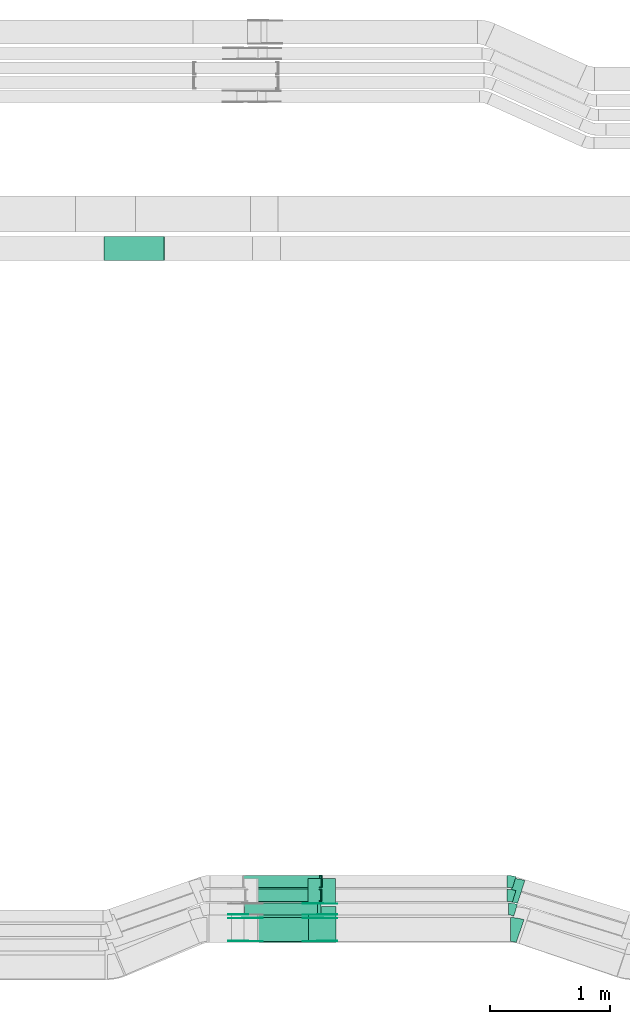
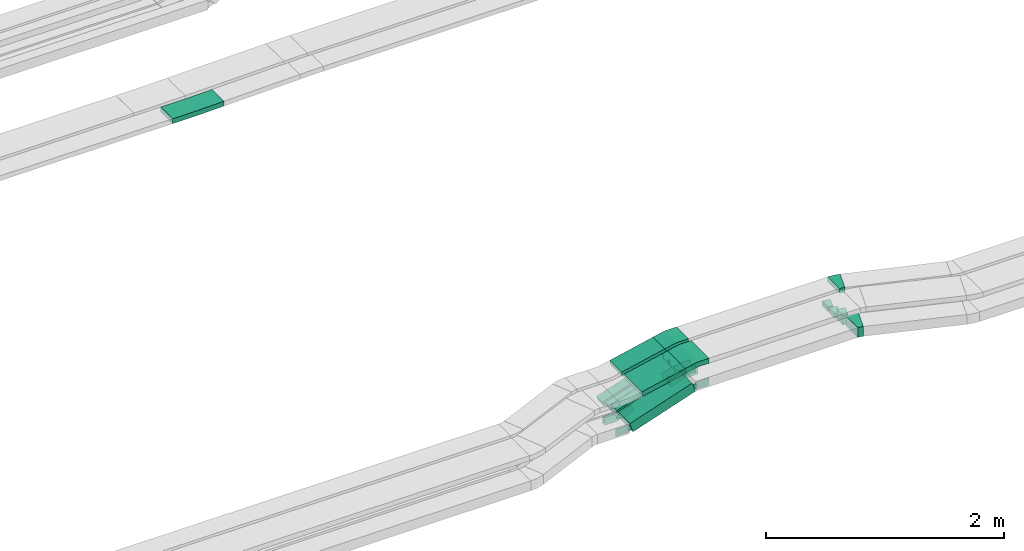
# One storey, part 10 of 28: 23 flow fittings, 6 flow segments.
"""IFC2X3 building model written with IfcOpenShell, lengths in millimetres."""

from ifc_helpers import new_model, entity, si_unit, converted_unit, derived_unit, direction, frame, frame_2d, origin, origin_2d_with_axis, place, context, subcontext, project, spatial, polyline, circle_curve, parameter, trimmed, segment, composite_curve, rectangle, outline, extrude, faceted_brep, source, transform, mapped, material, type_object, type_shapes, element, save


model = new_model("IFC2X3")

# Units and contexts
model_context = context("Model", 3, precision=0.01, world=origin(), true_north=direction((6.12303176911189e-17, 1.0)))
body_context = subcontext(model_context, "Body", "Model", "MODEL_VIEW")
ifc_project = project(units=[si_unit("LENGTHUNIT", "METRE", prefix="MILLI"), si_unit("AREAUNIT", "SQUARE_METRE"), si_unit("VOLUMEUNIT", "CUBIC_METRE"), converted_unit("PLANEANGLEUNIT", "DEGREE", entity("IfcRatioMeasure", 0.0174532925199433), si_unit("PLANEANGLEUNIT", "RADIAN"), dimensions=[0, 0, 0, 0, 0, 0, 0]), si_unit("MASSUNIT", "GRAM", prefix="KILO"), derived_unit("MASSDENSITYUNIT", [(si_unit("MASSUNIT", "GRAM", prefix="KILO"), 1), (si_unit("LENGTHUNIT", "METRE"), -3)]), derived_unit("MOMENTOFINERTIAUNIT", [(si_unit("LENGTHUNIT", "METRE"), 4)]), si_unit("TIMEUNIT", "SECOND"), si_unit("FREQUENCYUNIT", "HERTZ"), si_unit("THERMODYNAMICTEMPERATUREUNIT", "DEGREE_CELSIUS"), derived_unit("THERMALTRANSMITTANCEUNIT", [(si_unit("MASSUNIT", "GRAM", prefix="KILO"), 1), (si_unit("THERMODYNAMICTEMPERATUREUNIT", "KELVIN"), -1), (si_unit("TIMEUNIT", "SECOND"), -3)]), derived_unit("VOLUMETRICFLOWRATEUNIT", [(si_unit("LENGTHUNIT", "METRE"), 3), (si_unit("TIMEUNIT", "SECOND"), -1)]), derived_unit("MASSFLOWRATEUNIT", [(si_unit("MASSUNIT", "GRAM", prefix="KILO"), 1), (si_unit("TIMEUNIT", "SECOND"), -1)]), derived_unit("ROTATIONALFREQUENCYUNIT", [(si_unit("TIMEUNIT", "SECOND"), -1)]), si_unit("ELECTRICCURRENTUNIT", "AMPERE"), si_unit("ELECTRICVOLTAGEUNIT", "VOLT"), si_unit("POWERUNIT", "WATT"), si_unit("FORCEUNIT", "NEWTON", prefix="KILO"), si_unit("ILLUMINANCEUNIT", "LUX"), si_unit("LUMINOUSFLUXUNIT", "LUMEN"), si_unit("LUMINOUSINTENSITYUNIT", "CANDELA"), derived_unit("USERDEFINED", [(si_unit("MASSUNIT", "GRAM", prefix="KILO"), -1), (si_unit("LENGTHUNIT", "METRE"), -2), (si_unit("TIMEUNIT", "SECOND"), 3), (si_unit("LUMINOUSFLUXUNIT", "LUMEN"), 1)]), derived_unit("LINEARVELOCITYUNIT", [(si_unit("LENGTHUNIT", "METRE"), 1), (si_unit("TIMEUNIT", "SECOND"), -1)]), si_unit("PRESSUREUNIT", "PASCAL"), derived_unit("USERDEFINED", [(si_unit("LENGTHUNIT", "METRE"), -2), (si_unit("MASSUNIT", "GRAM", prefix="KILO"), 1), (si_unit("TIMEUNIT", "SECOND"), -2)]), derived_unit("LINEARFORCEUNIT", [(si_unit("MASSUNIT", "GRAM", prefix="KILO"), 1), (si_unit("LENGTHUNIT", "METRE"), 1), (si_unit("TIMEUNIT", "SECOND"), -2), (si_unit("LENGTHUNIT", "METRE"), -1)]), derived_unit("PLANARFORCEUNIT", [(si_unit("MASSUNIT", "GRAM", prefix="KILO"), 1), (si_unit("LENGTHUNIT", "METRE"), 1), (si_unit("TIMEUNIT", "SECOND"), -2), (si_unit("LENGTHUNIT", "METRE"), -2)])], contexts=[model_context])

# Site, building, storey
site_placement = place(None, origin())
site = spatial("IfcSite", under=ifc_project, at=site_placement, CompositionType="ELEMENT")
building_placement = place(site_placement, origin())
building = spatial("IfcBuilding", under=site, at=building_placement, CompositionType="ELEMENT")
storey_placement = place(building_placement, frame((0.0, 0.0, 15900.0)))
storey = spatial("IfcBuildingStorey", under=building, at=storey_placement, CompositionType="ELEMENT", Elevation=15900.0)

# Flow segments
cable_carrier_segment_type = type_object("IfcCableCarrierSegmentType", PredefinedType="CABLETRAYSEGMENT")
flow_segment_1_placement = place(storey_placement, frame((34367.86, 8525.15, 2844.72)))
element("IfcFlowSegment", 1, at=flow_segment_1_placement, inside=storey, type_object=cable_carrier_segment_type, context=body_context, shape_type="SweptSolid", body=[
    extrude(rectangle(XDim=50.0000000000015, YDim=300.000000000001, at=origin_2d_with_axis()), frame((5.31, 150.0, 24.43), z_axis=(0.977163348612744, 0.0, 0.212489505924243), x_axis=(-0.212489505924243, 0.0, 0.977163348612744)), (0.0, 0.0, 1.0), 431.573113149383),
])
flow_segment_2_placement = place(storey_placement, frame((34257.02, 8534.97, 2505.75)))
element("IfcFlowSegment", 2, at=flow_segment_2_placement, inside=storey, type_object=cable_carrier_segment_type, context=body_context, shape_type="SweptSolid", body=[
    extrude(rectangle(XDim=100.000000000002, YDim=200.0, at=origin_2d_with_axis()), frame((15.95, 100.0, 47.39), z_axis=(0.947738671950759, 0.0, 0.319047660528974), x_axis=(-0.319047660528974, 0.0, 0.947738671950759)), (0.0, 0.0, 1.0), 638.51802239172),
])
flow_segment_3_placement = place(storey_placement, frame((34364.23, 8860.15, 2844.77)))
element("IfcFlowSegment", 3, at=flow_segment_3_placement, inside=storey, type_object=cable_carrier_segment_type, context=body_context, shape_type="SweptSolid", body=[
    extrude(rectangle(XDim=50.0000000000002, YDim=200.0, at=origin_2d_with_axis()), frame((5.32, 100.0, 24.43), z_axis=(0.97707606826074, 0.0, 0.212890480839644), x_axis=(-0.212890480839644, 0.0, 0.97707606826074)), (0.0, 0.0, 1.0), 430.332278002831),
])
flow_segment_4_placement = place(storey_placement, frame((34259.3, 8755.15, 2505.75)))
element("IfcFlowSegment", 4, at=flow_segment_4_placement, inside=storey, type_object=cable_carrier_segment_type, context=body_context, shape_type="SweptSolid", body=[
    extrude(rectangle(XDim=100.0, YDim=99.9999999999989, at=origin_2d_with_axis()), frame((15.95, 50.0, 47.39), z_axis=(0.947738671950757, 0.0, 0.319047660528981), x_axis=(-0.319047660528981, 0.0, 0.947738671950757)), (0.0, 0.0, 1.0), 638.518022391706),
])
flow_segment_5_placement = place(storey_placement, frame((34268.27, 8870.15, 2503.92)))
element("IfcFlowSegment", 5, at=flow_segment_5_placement, inside=storey, type_object=cable_carrier_segment_type, context=body_context, shape_type="SweptSolid", body=[
    extrude(rectangle(XDim=50.0000000000011, YDim=100.000000000001, at=origin_2d_with_axis()), frame((7.98, 50.0, 23.69), z_axis=(0.947738671950759, 0.0, 0.319047660528974), x_axis=(-0.319047660528974, 0.0, 0.947738671950759)), (0.0, 0.0, 1.0), 643.826105191566),
])
flow_segment_6_placement = place(storey_placement, frame((34251.08, 8985.15, 2503.7)))
element("IfcFlowSegment", 6, at=flow_segment_6_placement, inside=storey, type_object=cable_carrier_segment_type, context=body_context, shape_type="SweptSolid", body=[
    extrude(rectangle(XDim=49.9999999999993, YDim=100.000000000001, at=origin_2d_with_axis()), frame((7.75, 50.0, 23.77), z_axis=(0.950702869556012, 0.0, 0.310103295400041), x_axis=(-0.310103295400041, 0.0, 0.950702869556012)), (0.0, 0.0, 1.0), 663.238349794011),
])

# Flow fittings
ifc_material_1 = material()
cable_carrier_fitting_type_1 = type_object("IfcCableCarrierFittingType", PredefinedType="NOTDEFINED", material=ifc_material_1)
shared_shape_1 = source(origin(), body_context, "Body", "Brep", [
    faceted_brep([(-8.19, 25.0, 50.0), (-8.19, 25.0, -50.0), (-8.19, -25.0, -50.0), (-8.19, -25.0, -47.46), (-8.19, 22.46, -47.46), (-8.19, 22.46, 47.46), (-8.19, -25.0, 47.46), (-8.19, -25.0, 50.0), (-0.21, 26.31, 50.0), (15.74, -21.08, 50.0), (15.74, -21.08, 47.46), (0.6, 23.9, 47.46), (0.6, 23.9, -47.46), (15.74, -21.08, -47.46), (15.74, -21.08, -50.0), (-0.21, 26.31, -50.0), (-4.1, 25.0, 50.0), (-4.1, 25.0, -50.0), (4.1, -25.0, -50.0), (4.1, -25.0, -47.46), (-3.68, 22.46, -47.46), (-3.68, 22.46, 47.46), (4.1, -25.0, 47.46), (4.1, -25.0, 50.0)], [[[0, 1, 2, 3, 4, 5, 6, 7]], [[8, 9, 10, 11, 12, 13, 14, 15]], [[1, 0, 16, 17]], [[2, 1, 17, 15, 14, 18]], [[3, 2, 18, 19]], [[4, 3, 19, 13, 12, 20]], [[5, 4, 20, 21]], [[6, 5, 21, 11, 10, 22]], [[7, 6, 22, 23]], [[0, 7, 23, 9, 8, 16]], [[17, 16, 8, 15]], [[19, 18, 14, 13]], [[21, 20, 12, 11]], [[23, 22, 10, 9]]]),
])
type_shapes(cable_carrier_fitting_type_1, [shared_shape_1])
flow_fitting_1_placement = place(storey_placement, frame((34894.19, 8920.15, 2735.64), z_axis=(0.0, -1.0, 0.0), x_axis=(-1.0, 0.0, 0.0)))
element("IfcFlowFitting", 7, at=flow_fitting_1_placement, inside=storey, type_object=cable_carrier_fitting_type_1, material=ifc_material_1, context=body_context, shape_type="MappedRepresentation", body=[
    mapped(shared_shape_1, transform((0.0, 0.0, 0.0), scale=1.0)),
])
cable_carrier_fitting_type_2 = type_object("IfcCableCarrierFittingType", PredefinedType="NOTDEFINED", material=ifc_material_1)
shared_shape_2 = source(origin(), body_context, "Body", "Brep", [
    faceted_brep([(-7.95, 25.0, 50.0), (-7.95, 25.0, -50.0), (-7.95, -25.0, -50.0), (-7.95, -25.0, -47.46), (-7.95, 22.46, -47.46), (-7.95, 22.46, 47.46), (-7.95, -25.0, 47.46), (-7.95, -25.0, 50.0), (-0.2, 26.23, 50.0), (15.31, -21.3, 50.0), (15.31, -21.3, 47.46), (0.59, 23.82, 47.46), (0.59, 23.82, -47.46), (15.31, -21.3, -47.46), (15.31, -21.3, -50.0), (-0.2, 26.23, -50.0), (-3.97, 25.0, 50.0), (-3.97, 25.0, -50.0), (3.97, -25.0, -50.0), (3.97, -25.0, -47.46), (-3.57, 22.46, -47.46), (-3.57, 22.46, 47.46), (3.97, -25.0, 47.46), (3.97, -25.0, 50.0)], [[[0, 1, 2, 3, 4, 5, 6, 7]], [[8, 9, 10, 11, 12, 13, 14, 15]], [[1, 0, 16, 17]], [[2, 1, 17, 15, 14, 18]], [[3, 2, 18, 19]], [[4, 3, 19, 13, 12, 20]], [[5, 4, 20, 21]], [[6, 5, 21, 11, 10, 22]], [[7, 6, 22, 23]], [[0, 7, 23, 9, 8, 16]], [[17, 16, 8, 15]], [[19, 18, 14, 13]], [[21, 20, 12, 11]], [[23, 22, 10, 9]]]),
])
type_shapes(cable_carrier_fitting_type_2, [shared_shape_2])
flow_fitting_2_placement = place(storey_placement, frame((34896.94, 9035.15, 2735.6), z_axis=(0.0, -1.0, 0.0), x_axis=(-1.0, 0.0, 0.0)))
element("IfcFlowFitting", 8, at=flow_fitting_2_placement, inside=storey, type_object=cable_carrier_fitting_type_2, material=ifc_material_1, context=body_context, shape_type="MappedRepresentation", body=[
    mapped(shared_shape_2, transform((0.0, 0.0, 0.0), scale=1.0)),
])
cable_carrier_fitting_type_3 = type_object("IfcCableCarrierFittingType", Name="470_DKC_S5_Variable Angle Elbow 0-45:-", PredefinedType="NOTDEFINED", material=ifc_material_1)
shared_shape_3 = source(origin(), body_context, "Body", "SweptSolid", [
    extrude(outline(composite_curve([segment(polyline([(-40.95, -106.64), (-39.95, -106.64)]), True, "CONTINUOUS"), segment(trimmed(circle_curve(frame_2d((-39.95, 243.36), x_axis=(0.0, -1.0)), 350.0), [parameter(0.0)], [parameter(18.6440270035289)], True, "PARAMETER"), True, "CONTINUOUS"), segment(polyline([(71.94, -88.27), (72.89, -87.95)]), True, "CONTINUOUS"), segment(polyline([(72.89, -87.95), (8.95, 101.55)]), True, "CONTINUOUS"), segment(polyline([(8.95, 101.55), (8.01, 101.23)]), True, "CONTINUOUS"), segment(trimmed(circle_curve(frame_2d((-39.95, 243.36), x_axis=(0.0, -1.0)), 150.0), [parameter(0.0)], [parameter(18.6440270035289)], True, "PARAMETER"), False, "CONTINUOUS"), segment(polyline([(-39.95, 93.36), (-40.95, 93.36)]), True, "CONTINUOUS"), segment(polyline([(-40.95, 93.36), (-40.95, -106.64)]), True, "CONTINUOUS")], self_intersect=False)), frame((-1.09, 6.64, -50.0)), (0.0, 0.0, 1.0), 100.0),
])
type_shapes(cable_carrier_fitting_type_3, [shared_shape_3])
flow_fitting_3_placement = place(storey_placement, frame((36511.19, 8634.97, 2760.0), z_axis=(0.0, 0.0, 1.0), x_axis=(-0.947523036731155, 0.319687495632485, 0.0)))
element("IfcFlowFitting", 9, at=flow_fitting_3_placement, inside=storey, type_object=cable_carrier_fitting_type_3, material=ifc_material_1, Name="470_DKC_S5_Variable Angle Elbow 0-45:-", ObjectType="470_DKC_S5_Variable Angle Elbow 0-45:-", context=body_context, shape_type="MappedRepresentation", body=[
    mapped(shared_shape_3, transform((0.0, 0.0, 0.0), scale=1.0)),
])
cable_carrier_fitting_type_4 = type_object("IfcCableCarrierFittingType", Name="470_DKC_S5_Variable Angle Elbow 0-45:-", PredefinedType="NOTDEFINED", material=ifc_material_1)
shared_shape_4 = source(origin(), body_context, "Body", "SweptSolid", [
    extrude(outline(composite_curve([segment(polyline([(-39.98, -106.32), (-38.98, -106.32)]), True, "CONTINUOUS"), segment(trimmed(circle_curve(frame_2d((-38.98, 243.68), x_axis=(0.0, -1.0)), 350.0), [parameter(0.0)], [parameter(18.1782774573338)], True, "PARAMETER"), True, "CONTINUOUS"), segment(polyline([(70.21, -88.85), (71.16, -88.54)]), True, "CONTINUOUS"), segment(polyline([(71.16, -88.54), (8.76, 101.48)]), True, "CONTINUOUS"), segment(polyline([(8.76, 101.48), (7.81, 101.17)]), True, "CONTINUOUS"), segment(trimmed(circle_curve(frame_2d((-38.98, 243.68), x_axis=(0.0, -1.0)), 150.0), [parameter(0.0)], [parameter(18.1782774573338)], True, "PARAMETER"), False, "CONTINUOUS"), segment(polyline([(-38.98, 93.68), (-39.98, 93.68)]), True, "CONTINUOUS"), segment(polyline([(-39.98, 93.68), (-39.98, -106.32)]), True, "CONTINUOUS")], self_intersect=False)), frame((-1.01, 6.32, -25.0)), (0.0, 0.0, 1.0), 50.0000000000005),
])
type_shapes(cable_carrier_fitting_type_4, [shared_shape_4])
flow_fitting_4_placement = place(storey_placement, frame((36520.92, 8960.15, 2985.0), z_axis=(0.0, 0.0, 1.0), x_axis=(-0.950090398751314, 0.311974733272694, 0.0)))
element("IfcFlowFitting", 10, at=flow_fitting_4_placement, inside=storey, type_object=cable_carrier_fitting_type_4, material=ifc_material_1, Name="470_DKC_S5_Variable Angle Elbow 0-45:-", ObjectType="470_DKC_S5_Variable Angle Elbow 0-45:-", context=body_context, shape_type="MappedRepresentation", body=[
    mapped(shared_shape_4, transform((0.0, 0.0, 0.0), scale=1.0)),
])
cable_carrier_fitting_type_5 = type_object("IfcCableCarrierFittingType", Name="470_DKC_S5_Variable Angle Elbow 0-45:-", PredefinedType="NOTDEFINED", material=ifc_material_1)
shared_shape_5 = source(origin(), body_context, "Body", "SweptSolid", [
    extrude(outline(composite_curve([segment(polyline([(-30.38, -54.49), (-29.38, -54.49)]), True, "CONTINUOUS"), segment(trimmed(circle_curve(frame_2d((-29.38, 195.51), x_axis=(0.0, -1.0)), 250.0), [parameter(0.0)], [parameter(17.0938540056396)], True, "PARAMETER"), True, "CONTINUOUS"), segment(polyline([(44.1, -43.45), (45.06, -43.15)]), True, "CONTINUOUS"), segment(polyline([(45.06, -43.15), (15.66, 52.43)]), True, "CONTINUOUS"), segment(polyline([(15.66, 52.43), (14.71, 52.14)]), True, "CONTINUOUS"), segment(trimmed(circle_curve(frame_2d((-29.38, 195.51), x_axis=(0.0, -1.0)), 150.0), [parameter(0.0)], [parameter(17.0938540056396)], True, "PARAMETER"), False, "CONTINUOUS"), segment(polyline([(-29.38, 45.51), (-30.38, 45.51)]), True, "CONTINUOUS"), segment(polyline([(-30.38, 45.51), (-30.38, -54.49)]), True, "CONTINUOUS")], self_intersect=False)), frame((-0.67, 4.49, -50.0)), (0.0, 0.0, 1.0), 100.0),
])
type_shapes(cable_carrier_fitting_type_5, [shared_shape_5])
flow_fitting_5_placement = place(storey_placement, frame((36483.86, 8805.15, 2760.0), z_axis=(0.0, 0.0, 1.0), x_axis=(-0.955824550369197, 0.293937797691149, 0.0)))
element("IfcFlowFitting", 11, at=flow_fitting_5_placement, inside=storey, type_object=cable_carrier_fitting_type_5, material=ifc_material_1, Name="470_DKC_S5_Variable Angle Elbow 0-45:-", ObjectType="470_DKC_S5_Variable Angle Elbow 0-45:-", context=body_context, shape_type="MappedRepresentation", body=[
    mapped(shared_shape_5, transform((0.0, 0.0, 0.0), scale=1.0)),
])
cable_carrier_fitting_type_6 = type_object("IfcCableCarrierFittingType", Name="470_DKC_S5_Variable Angle Elbow 0-45:-", PredefinedType="NOTDEFINED", material=ifc_material_1)
shared_shape_6 = source(origin(), body_context, "Body", "SweptSolid", [
    extrude(outline(composite_curve([segment(polyline([(-30.38, -54.49), (-29.38, -54.49)]), True, "CONTINUOUS"), segment(trimmed(circle_curve(frame_2d((-29.38, 195.51), x_axis=(0.0, -1.0)), 250.0), [parameter(0.0)], [parameter(17.0938540056406)], True, "PARAMETER"), True, "CONTINUOUS"), segment(polyline([(44.1, -43.45), (45.06, -43.15)]), True, "CONTINUOUS"), segment(polyline([(45.06, -43.15), (15.66, 52.43)]), True, "CONTINUOUS"), segment(polyline([(15.66, 52.43), (14.71, 52.14)]), True, "CONTINUOUS"), segment(trimmed(circle_curve(frame_2d((-29.38, 195.51), x_axis=(0.0, -1.0)), 150.0), [parameter(0.0)], [parameter(17.0938540056406)], True, "PARAMETER"), False, "CONTINUOUS"), segment(polyline([(-29.38, 45.51), (-30.38, 45.51)]), True, "CONTINUOUS"), segment(polyline([(-30.38, 45.51), (-30.38, -54.49)]), True, "CONTINUOUS")], self_intersect=False)), frame((-0.67, 4.49, -25.0)), (0.0, 0.0, 1.0), 50.0000000000001),
])
type_shapes(cable_carrier_fitting_type_6, [shared_shape_6])
for number, where, z_axis, x_axis, name in (
    (12, (36471.76, 8920.15, 2735.64), (0.0, 0.0, 1.0), (-0.955824550369197, 0.293937797691149, 0.0), "470_DKC_S5_Variable Angle Elbow 0-45:-"),
    (13, (36471.76, 9035.15, 2735.6), (0.0, 0.0, 1.0), (-0.955824550369191, 0.293937797691167, 0.0), "470_DKC_S5_Variable Angle Elbow 0-45:-"),
):
    element("IfcFlowFitting", number, at=place(storey_placement, frame(where, z_axis=z_axis, x_axis=x_axis)), inside=storey, type_object=cable_carrier_fitting_type_6, material=ifc_material_1, Name=name, ObjectType="470_DKC_S5_Variable Angle Elbow 0-45:-", context=body_context, shape_type="MappedRepresentation", body=[
        mapped(shared_shape_6, transform((0.0, 0.0, 0.0), scale=1.0)),
    ])
cable_carrier_fitting_type_7 = type_object("IfcCableCarrierFittingType", Name="470_DKC_S5_CD 90 external vertical angle:-", PredefinedType="NOTDEFINED", material=ifc_material_1)
shared_shape_7 = source(origin(), body_context, "Body", "SweptSolid", [
    extrude(outline(composite_curve([segment(polyline([(-112.89, -31.98), (-16.98, -31.98)]), True, "CONTINUOUS"), segment(trimmed(circle_curve(frame_2d((-16.98, 158.02), x_axis=(0.0, -1.0)), 189.999999999999), [parameter(0.0)], [parameter(12.2682836771792)], True, "PARAMETER"), True, "CONTINUOUS"), segment(polyline([(23.39, -27.64), (117.11, -7.26)]), True, "CONTINUOUS"), segment(polyline([(117.11, -7.26), (106.48, 41.6)]), True, "CONTINUOUS"), segment(polyline([(106.48, 41.6), (12.77, 21.22)]), True, "CONTINUOUS"), segment(trimmed(circle_curve(frame_2d((-16.98, 158.02), x_axis=(0.0, -1.0)), 139.999999999999), [parameter(0.0)], [parameter(12.2682836771792)], True, "PARAMETER"), False, "CONTINUOUS"), segment(polyline([(-16.98, 18.02), (-112.89, 18.02)]), True, "CONTINUOUS"), segment(polyline([(-112.89, 18.02), (-112.89, -31.98)]), True, "CONTINUOUS")], self_intersect=False)), frame((-0.75, 6.98, -150.0)), (0.0, 0.0, 1.0), 300.0),
])
type_shapes(cable_carrier_fitting_type_7, [shared_shape_7])
flow_fitting_6_placement = place(storey_placement, frame((34905.94, 8675.15, 2985.0), z_axis=(0.0, -1.0, 0.0), x_axis=(-1.0, 0.0, 0.0)))
element("IfcFlowFitting", 14, at=flow_fitting_6_placement, inside=storey, type_object=cable_carrier_fitting_type_7, material=ifc_material_1, Name="470_DKC_S5_CD 90 external vertical angle:-", ObjectType="470_DKC_S5_CD 90 external vertical angle:-", context=body_context, shape_type="MappedRepresentation", body=[
    mapped(shared_shape_7, transform((0.0, 0.0, 0.0), scale=1.0)),
])
cable_carrier_fitting_type_8 = type_object("IfcCableCarrierFittingType", Name="470_DKC_S5_CD 90 external vertical angle:-", PredefinedType="NOTDEFINED", material=ifc_material_1)
shared_shape_8 = source(origin(), body_context, "Body", "SweptSolid", [
    extrude(outline(composite_curve([segment(polyline([(-112.89, -31.99), (-17.01, -31.99)]), True, "CONTINUOUS"), segment(trimmed(circle_curve(frame_2d((-17.01, 158.01), x_axis=(0.0, -1.0)), 189.999999999999), [parameter(0.0)], [parameter(12.2917958116951)], True, "PARAMETER"), True, "CONTINUOUS"), segment(polyline([(23.44, -27.64), (117.11, -7.23)]), True, "CONTINUOUS"), segment(polyline([(117.11, -7.23), (106.47, 41.63)]), True, "CONTINUOUS"), segment(polyline([(106.47, 41.63), (12.79, 21.22)]), True, "CONTINUOUS"), segment(trimmed(circle_curve(frame_2d((-17.01, 158.01), x_axis=(0.0, -1.0)), 139.999999999999), [parameter(0.0)], [parameter(12.2917958116951)], True, "PARAMETER"), False, "CONTINUOUS"), segment(polyline([(-17.01, 18.01), (-112.89, 18.01)]), True, "CONTINUOUS"), segment(polyline([(-112.89, 18.01), (-112.89, -31.99)]), True, "CONTINUOUS")], self_intersect=False)), frame((-0.75, 6.99, -100.0)), (0.0, 0.0, 1.0), 200.0),
])
type_shapes(cable_carrier_fitting_type_8, [shared_shape_8])
flow_fitting_7_placement = place(storey_placement, frame((34901.06, 8960.15, 2985.0), z_axis=(0.0, -1.0, 0.0), x_axis=(-1.0, 0.0, 0.0)))
element("IfcFlowFitting", 15, at=flow_fitting_7_placement, inside=storey, type_object=cable_carrier_fitting_type_8, material=ifc_material_1, Name="470_DKC_S5_CD 90 external vertical angle:-", ObjectType="470_DKC_S5_CD 90 external vertical angle:-", context=body_context, shape_type="MappedRepresentation", body=[
    mapped(shared_shape_8, transform((0.0, 0.0, 0.0), scale=1.0)),
])
ifc_material_2 = material(Name="G")
cable_carrier_fitting_type_9 = type_object("IfcCableCarrierFittingType", PredefinedType="NOTDEFINED", material=ifc_material_2)
shared_shape_9 = source(origin(), body_context, "Body", "SweptSolid", [
    extrude(outline(composite_curve([segment(trimmed(circle_curve(frame_2d((-41.47, 0.0), x_axis=(1.0, 0.0)), 25.0), [parameter(90.0000000000007)], [parameter(270.0)], True, "PARAMETER"), True, "CONTINUOUS"), segment(polyline([(-41.47, -25.0), (-29.97, -25.0)]), True, "CONTINUOUS"), segment(polyline([(-29.97, -25.0), (-28.1, -38.5)]), True, "CONTINUOUS"), segment(polyline([(-28.1, -38.5), (99.53, -38.5)]), True, "CONTINUOUS"), segment(polyline([(99.53, -38.5), (99.53, 38.5)]), True, "CONTINUOUS"), segment(polyline([(99.53, 38.5), (-28.1, 38.5)]), True, "CONTINUOUS"), segment(polyline([(-28.1, 38.5), (-29.97, 25.0)]), True, "CONTINUOUS"), segment(polyline([(-29.97, 25.0), (-41.47, 25.0)]), True, "CONTINUOUS")], self_intersect=False)), frame((41.47, 0.0, 0.0), z_axis=(0.0, 0.0, -1.0), x_axis=(1.0, 0.0, 0.0)), (0.0, 0.0, -1.0), 2.0),
])
type_shapes(cable_carrier_fitting_type_9, [shared_shape_9])
flow_fitting_8_placement = place(storey_placement, frame((34889.73, 8759.69, 2760.0), z_axis=(0.0, -1.0, 0.0), x_axis=(-0.947738671950754, 0.0, -0.319047660528989)))
element("IfcFlowFitting", 16, at=flow_fitting_8_placement, inside=storey, type_object=cable_carrier_fitting_type_9, material=ifc_material_2, context=body_context, shape_type="MappedRepresentation", body=[
    mapped(shared_shape_9, transform((0.0, 0.0, 0.0), scale=1.0)),
])
cable_carrier_fitting_type_10 = type_object("IfcCableCarrierFittingType", PredefinedType="NOTDEFINED", material=ifc_material_2)
type_shapes(cable_carrier_fitting_type_10, [shared_shape_9])
flow_fitting_9_placement = place(storey_placement, frame((34889.73, 8848.61, 2760.0), z_axis=(0.0, 1.0, 0.0), x_axis=(1.0, 0.0, 0.0)))
element("IfcFlowFitting", 17, at=flow_fitting_9_placement, inside=storey, type_object=cable_carrier_fitting_type_10, material=ifc_material_2, context=body_context, shape_type="MappedRepresentation", body=[
    mapped(shared_shape_9, transform((0.0, 0.0, 0.0), scale=1.0)),
])
flow_fitting_10_placement = place(storey_placement, frame((34887.45, 8539.51, 2760.0), z_axis=(0.0, -1.0, 0.0), x_axis=(-0.947738671950754, 0.0, -0.319047660528989)))
element("IfcFlowFitting", 18, at=flow_fitting_10_placement, inside=storey, type_object=cable_carrier_fitting_type_9, material=ifc_material_2, context=body_context, shape_type="MappedRepresentation", body=[
    mapped(shared_shape_9, transform((0.0, 0.0, 0.0), scale=1.0)),
])
flow_fitting_11_placement = place(storey_placement, frame((34887.45, 8728.43, 2760.0), z_axis=(0.0, 1.0, 0.0), x_axis=(1.0, 0.0, 0.0)))
element("IfcFlowFitting", 19, at=flow_fitting_11_placement, inside=storey, type_object=cable_carrier_fitting_type_10, material=ifc_material_2, context=body_context, shape_type="MappedRepresentation", body=[
    mapped(shared_shape_9, transform((0.0, 0.0, 0.0), scale=1.0)),
])
flow_fitting_12_placement = place(storey_placement, frame((34263.64, 8539.51, 2550.0), z_axis=(0.0, -1.0, 0.0), x_axis=(0.947738671950754, 0.0, 0.319047660528989)))
element("IfcFlowFitting", 20, at=flow_fitting_12_placement, inside=storey, type_object=cable_carrier_fitting_type_9, material=ifc_material_2, context=body_context, shape_type="MappedRepresentation", body=[
    mapped(shared_shape_9, transform((0.0, 0.0, 0.0), scale=1.0)),
])
flow_fitting_13_placement = place(storey_placement, frame((34263.64, 8728.43, 2550.0), z_axis=(0.0, 1.0, 0.0), x_axis=(-1.0, 0.0, 0.0)))
element("IfcFlowFitting", 21, at=flow_fitting_13_placement, inside=storey, type_object=cable_carrier_fitting_type_10, material=ifc_material_2, context=body_context, shape_type="MappedRepresentation", body=[
    mapped(shared_shape_9, transform((0.0, 0.0, 0.0), scale=1.0)),
])
cable_carrier_fitting_type_11 = type_object("IfcCableCarrierFittingType", PredefinedType="NOTDEFINED", material=ifc_material_2)
shared_shape_10 = source(origin(), body_context, "Body", "SweptSolid", [
    extrude(outline(composite_curve([segment(trimmed(circle_curve(frame_2d((-41.47, 0.0), x_axis=(1.0, 0.0)), 25.0), [parameter(90.0000000000007)], [parameter(270.0)], True, "PARAMETER"), True, "CONTINUOUS"), segment(polyline([(-41.47, -25.0), (-29.97, -25.0)]), True, "CONTINUOUS"), segment(polyline([(-29.97, -25.0), (-28.1, -38.5)]), True, "CONTINUOUS"), segment(polyline([(-28.1, -38.5), (99.53, -38.5)]), True, "CONTINUOUS"), segment(polyline([(99.53, -38.5), (99.53, 38.5)]), True, "CONTINUOUS"), segment(polyline([(99.53, 38.5), (-28.1, 38.5)]), True, "CONTINUOUS"), segment(polyline([(-28.1, 38.5), (-29.97, 25.0)]), True, "CONTINUOUS"), segment(polyline([(-29.97, 25.0), (-41.47, 25.0)]), True, "CONTINUOUS")], self_intersect=False)), frame((41.47, 0.0, 0.0)), (0.0, 0.0, 1.0), 2.0),
])
type_shapes(cable_carrier_fitting_type_11, [shared_shape_10])
flow_fitting_14_placement = place(storey_placement, frame((34889.73, 8850.61, 2760.0), z_axis=(0.0, 1.0, 0.0), x_axis=(-0.947738671950754, 0.0, -0.319047660528989)))
element("IfcFlowFitting", 22, at=flow_fitting_14_placement, inside=storey, type_object=cable_carrier_fitting_type_11, material=ifc_material_2, context=body_context, shape_type="MappedRepresentation", body=[
    mapped(shared_shape_10, transform((0.0, 0.0, 0.0), scale=1.0)),
])
cable_carrier_fitting_type_12 = type_object("IfcCableCarrierFittingType", PredefinedType="NOTDEFINED", material=ifc_material_2)
type_shapes(cable_carrier_fitting_type_12, [shared_shape_10])
for number, where, z_axis, x_axis in (
    (23, (34889.73, 8761.69, 2760.0), (0.0, -1.0, 0.0), (1.0, 0.0, 0.0)),
    (24, (34265.92, 8761.69, 2550.0), (0.0, -1.0, 0.0), (-1.0, 0.0, 0.0)),
):
    element("IfcFlowFitting", number, at=place(storey_placement, frame(where, z_axis=z_axis, x_axis=x_axis)), inside=storey, type_object=cable_carrier_fitting_type_12, material=ifc_material_2, context=body_context, shape_type="MappedRepresentation", body=[
        mapped(shared_shape_10, transform((0.0, 0.0, 0.0), scale=1.0)),
    ])
flow_fitting_15_placement = place(storey_placement, frame((34887.45, 8730.43, 2760.0), z_axis=(0.0, 1.0, 0.0), x_axis=(-0.947738671950754, 0.0, -0.319047660528989)))
element("IfcFlowFitting", 25, at=flow_fitting_15_placement, inside=storey, type_object=cable_carrier_fitting_type_11, material=ifc_material_2, context=body_context, shape_type="MappedRepresentation", body=[
    mapped(shared_shape_10, transform((0.0, 0.0, 0.0), scale=1.0)),
])
flow_fitting_16_placement = place(storey_placement, frame((34887.45, 8541.51, 2760.0), z_axis=(0.0, -1.0, 0.0), x_axis=(1.0, 0.0, 0.0)))
element("IfcFlowFitting", 26, at=flow_fitting_16_placement, inside=storey, type_object=cable_carrier_fitting_type_12, material=ifc_material_2, context=body_context, shape_type="MappedRepresentation", body=[
    mapped(shared_shape_10, transform((0.0, 0.0, 0.0), scale=1.0)),
])
flow_fitting_17_placement = place(storey_placement, frame((34263.64, 8730.43, 2550.0), z_axis=(0.0, 1.0, 0.0), x_axis=(0.947738671950754, 0.0, 0.319047660528989)))
element("IfcFlowFitting", 27, at=flow_fitting_17_placement, inside=storey, type_object=cable_carrier_fitting_type_11, material=ifc_material_2, context=body_context, shape_type="MappedRepresentation", body=[
    mapped(shared_shape_10, transform((0.0, 0.0, 0.0), scale=1.0)),
])
flow_fitting_18_placement = place(storey_placement, frame((34263.64, 8541.51, 2550.0), z_axis=(0.0, -1.0, 0.0), x_axis=(-1.0, 0.0, 0.0)))
element("IfcFlowFitting", 28, at=flow_fitting_18_placement, inside=storey, type_object=cable_carrier_fitting_type_12, material=ifc_material_2, context=body_context, shape_type="MappedRepresentation", body=[
    mapped(shared_shape_10, transform((0.0, 0.0, 0.0), scale=1.0)),
])
cable_carrier_fitting_type_13 = type_object("IfcCableCarrierFittingType", Name="470_DKC_S5_CS 90 internal vertical angle:-", PredefinedType="NOTDEFINED", material=ifc_material_1)
shared_shape_11 = source(origin(), body_context, "Body", "SweptSolid", [
    extrude(outline(composite_curve([segment(polyline([(-249.73, -26.43), (-1.57, -26.43)]), True, "CONTINUOUS"), segment(trimmed(circle_curve(frame_2d((-1.57, 138.57), x_axis=(0.0, -1.0)), 164.999999999999), [parameter(0.0)], [parameter(1.30045175841095)], True, "PARAMETER"), True, "CONTINUOUS"), segment(polyline([(2.17, -26.38), (250.27, -20.75)]), True, "CONTINUOUS"), segment(polyline([(250.27, -20.75), (249.13, 29.24)]), True, "CONTINUOUS"), segment(polyline([(249.13, 29.24), (1.04, 23.6)]), True, "CONTINUOUS"), segment(trimmed(circle_curve(frame_2d((-1.57, 138.57), x_axis=(0.0, -1.0)), 114.999999999999), [parameter(0.0)], [parameter(1.30045175841095)], True, "PARAMETER"), False, "CONTINUOUS"), segment(polyline([(-1.57, 23.57), (-249.73, 23.57)]), True, "CONTINUOUS"), segment(polyline([(-249.73, 23.57), (-249.73, -26.43)]), True, "CONTINUOUS")], self_intersect=False)), frame((-0.02, 1.43, -100.0)), (0.0, 0.0, 1.0), 200.0),
])
type_shapes(cable_carrier_fitting_type_13, [shared_shape_11])
flow_fitting_19_placement = place(storey_placement, frame((33340.92, 14300.03, 2675.0), z_axis=(0.0, 1.0, 0.0), x_axis=(-0.999742430409445, 0.0, -0.0226952162143693)))
element("IfcFlowFitting", 29, at=flow_fitting_19_placement, inside=storey, type_object=cable_carrier_fitting_type_13, material=ifc_material_1, Name="470_DKC_S5_CS 90 internal vertical angle:-", ObjectType="470_DKC_S5_CS 90 internal vertical angle:-", context=body_context, shape_type="MappedRepresentation", body=[
    mapped(shared_shape_11, transform((0.0, 0.0, 0.0), scale=1.0)),
])

save(model, "model.ifc")
